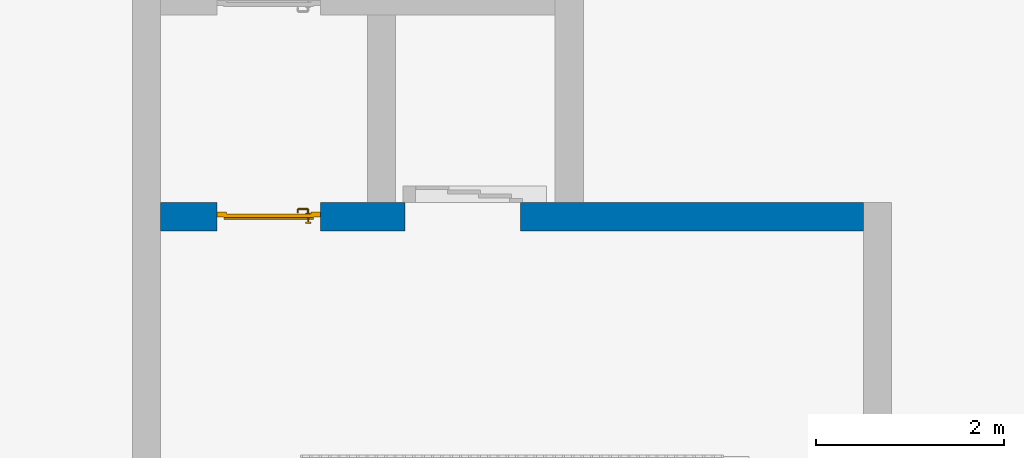
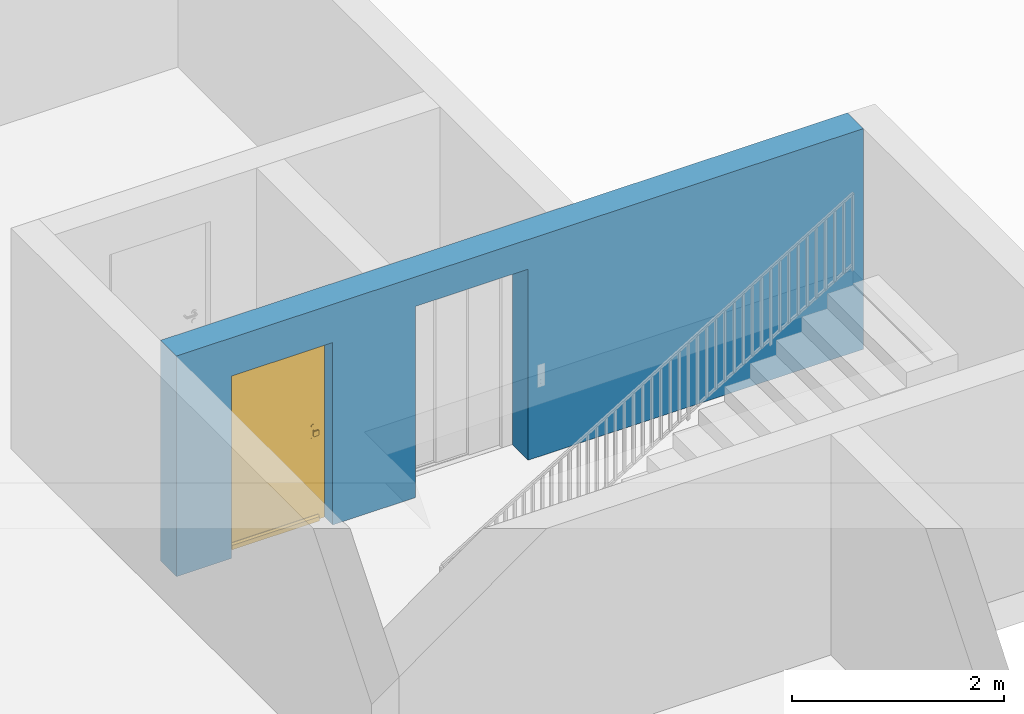
# One storey, part 3 of 6: 1 door, 1 wall, 2 openings.
"""IFC4 building model written with IfcOpenShell, lengths in metres."""

from ifc_helpers import new_model, entity, si_unit, converted_unit, derived_unit, direction, frame, origin_with_axes, place, context, subcontext, project, spatial, polygons, material, type_object, element, fill, save


model = new_model("IFC4")

# Units and contexts
model_context = context("Model", 3, precision=1e-05, world=origin_with_axes(), true_north=direction((0.0, 1.0)))
body_context = subcontext(model_context, "Body", "Model", "MODEL_VIEW")
ifc_project = project(units=[si_unit("LENGTHUNIT", "METRE"), si_unit("AREAUNIT", "SQUARE_METRE"), si_unit("VOLUMEUNIT", "CUBIC_METRE"), converted_unit("PLANEANGLEUNIT", "DEGREE", entity("IfcPlaneAngleMeasure", 0.0174532925199), si_unit("PLANEANGLEUNIT", "RADIAN"), dimensions=[0, 0, 0, 0, 0, 0, 0]), converted_unit("TIMEUNIT", "Year", entity("IfcTimeMeasure", 31556926.0), si_unit("TIMEUNIT", "SECOND"), dimensions=[0, 0, 1, 0, 0, 0, 0]), si_unit("MASSUNIT", "GRAM", prefix="KILO"), si_unit("THERMODYNAMICTEMPERATUREUNIT", "DEGREE_CELSIUS"), si_unit("LUMINOUSINTENSITYUNIT", "LUMEN"), si_unit("ENERGYUNIT", "JOULE", prefix="MEGA"), derived_unit("THERMALCONDUCTANCEUNIT", [(si_unit("POWERUNIT", "WATT"), 1), (si_unit("LENGTHUNIT", "METRE"), -1), (si_unit("THERMODYNAMICTEMPERATUREUNIT", "KELVIN"), -1)]), derived_unit("SPECIFICHEATCAPACITYUNIT", [(si_unit("ENERGYUNIT", "JOULE"), 1), (si_unit("MASSUNIT", "GRAM", prefix="KILO"), -1), (si_unit("THERMODYNAMICTEMPERATUREUNIT", "KELVIN"), -1)]), derived_unit("MASSDENSITYUNIT", [(si_unit("MASSUNIT", "GRAM", prefix="KILO"), 1), (si_unit("VOLUMEUNIT", "CUBIC_METRE"), -1)])], contexts=[model_context])

# Site, building, storey
site_placement = place(None, origin_with_axes())
site = spatial("IfcSite", under=ifc_project, at=site_placement, CompositionType="ELEMENT")
building_placement = place(site_placement, origin_with_axes())
building = spatial("IfcBuilding", under=site, at=building_placement, CompositionType="ELEMENT")
storey_placement = place(building_placement, frame((0.0, 0.0, -2.89), z_axis=(0.0, 0.0, 1.0), x_axis=(1.0, 0.0, 0.0)))
storey = spatial("IfcBuildingStorey", under=building, at=storey_placement, Name="-1. Geschoss", CompositionType="ELEMENT", Elevation=-2.89)

# Wall, openings, door
ifc_material = material()
wall_type = type_object("IfcWallType", Name="300", PredefinedType="NOTDEFINED")
wall_placement = place(storey_placement, frame((-5.2421993804, 1.37118776896, 0.0), z_axis=(0.0, 0.0, 1.0), x_axis=(1.0, 0.0, 0.0)))
wall = element("IfcWall", 1, at=wall_placement, inside=storey, type_object=wall_type, material=ifc_material, Name="Wand-001", PredefinedType="NOTDEFINED", context=body_context, shape_type="Tessellation", body=[
    polygons([(2.9, 0.3, 2.2), (2.9, 0.3, 0.0), (2.0, 0.3, 0.0), (2.0, 0.3, 2.1), (0.9, 0.3, 2.1), (0.9, 0.3, 0.0), (0.3, 0.3, 0.0), (0.3, 0.3, 2.54), (7.78, 0.3, 2.54), (7.78, 0.3, 0.0), (4.13, 0.3, 0.0), (4.13, 0.3, 2.2), (2.9, 0.0, 2.2), (2.9, 0.0, 0.0), (2.0, 0.0, 0.0), (2.0, 0.0, 2.1), (0.9, 0.0, 2.1), (0.9, 0.0, 0.0), (0.3, 0.0, 0.0), (0.3, 0.0, 2.54), (7.78, 0.0, 2.54), (7.78, 0.0, 0.0), (4.13, 0.0, 0.0), (4.13, 0.0, 2.2)], [[[1, 2, 3, 4, 5, 6, 7, 8, 9, 10, 11, 12]], [[2, 1, 13, 14]], [[2, 14, 15, 3]], [[3, 15, 16, 4]], [[4, 16, 17, 5]], [[5, 17, 18, 6]], [[18, 19, 7, 6]], [[7, 19, 20, 8]], [[8, 20, 21, 9]], [[22, 10, 9, 21]], [[23, 11, 10, 22]], [[12, 11, 23, 24]], [[1, 12, 24, 13]], [[24, 23, 22, 21, 20, 19, 18, 17, 16, 15, 14, 13]]], closed=True),
])
opening_1_placement = place(wall_placement, frame((1.45, 0.0, 0.0), z_axis=(0.0, 0.0, 1.0), x_axis=(1.0, 0.0, 0.0)))
opening_1 = element("IfcOpeningElement", 2, at=opening_1_placement, cuts=wall, context=body_context, identifier="Reference", shape_type="Tessellation", body=[
    polygons([(0.55, 0.15, 0.0), (0.55, 0.15, 2.1), (0.55, -0.001, 2.1), (0.55, -0.001, 0.0), (0.55, 0.301, 0.0), (0.55, 0.301, 2.1), (-0.55, 0.15, 2.1), (-0.55, -0.001, 2.1), (-0.55, 0.301, 2.1), (-0.55, -0.001, 0.0), (-0.55, 0.15, 0.0), (-0.55, 0.301, 0.0)], [[[1, 2, 3, 4]], [[2, 1, 5, 6]], [[7, 8, 3, 2, 6, 9]], [[8, 10, 4, 3]], [[1, 4, 10, 11, 12, 5]], [[6, 5, 12, 9]], [[7, 11, 10, 8]], [[11, 7, 9, 12]]], closed=True),
])
opening_2_placement = place(wall_placement, frame((3.515, 0.0, 0.0), z_axis=(0.0, 0.0, 1.0), x_axis=(1.0, 0.0, 0.0)))
element("IfcOpeningElement", 3, at=opening_2_placement, cuts=wall, context=body_context, identifier="Reference", shape_type="Tessellation", body=[
    polygons([(-0.615, -0.001, 2.2), (-0.615, -0.001, 0.0), (0.615, -0.001, 0.0), (0.615, -0.001, 2.2), (-0.615, 0.301, 2.2), (-0.615, 0.301, 0.0), (0.615, 0.301, 0.0), (0.615, 0.301, 2.2)], [[[1, 2, 3, 4]], [[5, 6, 2, 1]], [[6, 7, 3, 2]], [[7, 8, 4, 3]], [[8, 5, 1, 4]], [[7, 6, 5, 8]]], closed=True),
])
door_type = type_object("IfcDoorType", Name="Eingang 01 1-Fl 26", OperationType="SINGLE_SWING_RIGHT", PredefinedType="DOOR")
door_placement = place(opening_1_placement, frame((0.45, 0.0, 0.0), z_axis=(0.0, 0.0, 1.0), x_axis=(-1.0, 0.0, 0.0)))
door = element("IfcDoor", 4, at=door_placement, inside=storey, type_object=door_type, OverallHeight=2.1, OverallWidth=1.1, PredefinedType="DOOR", context=body_context, shape_type="Tessellation", body=[
    polygons([(1.0, -0.2, 0.0), (1.0, -0.18, 0.0), (1.0, -0.18, 2.1), (1.0, -0.2, 2.1), (0.9, -0.2, 0.0), (0.9, -0.18, 0.0), (0.9, -0.18, 2.0), (0.5801, -0.18, 2.0), (0.4501, -0.18, 2.0), (0.0, -0.18, 2.0), (0.0, -0.18, 0.0), (-0.1, -0.18, 0.0), (-0.1, -0.18, 2.1), (-0.1, -0.2, 2.1), (-0.1, -0.2, 0.0), (0.0, -0.2, 0.0), (0.0, -0.2, 2.0), (0.4501, -0.2, 2.0), (0.5801, -0.2, 2.0), (0.9, -0.2, 2.0)], [[[1, 2, 3, 4]], [[5, 6, 2, 1]], [[2, 6, 7, 8, 9, 10, 11, 12, 13, 3]], [[4, 3, 13, 14]], [[1, 4, 14, 15, 16, 17, 18, 19, 20, 5]], [[20, 7, 6, 5]], [[19, 8, 7, 20]], [[18, 9, 8, 19]], [[17, 10, 9, 18]], [[16, 11, 10, 17]], [[15, 12, 11, 16]], [[14, 13, 12, 15]]], closed=True),
    polygons([(1.0, -0.18, 0.0), (1.0, -0.15, 0.0), (1.0, -0.15, 2.1), (1.0, -0.18, 2.1), (0.93, -0.18, 0.0), (0.93, -0.15, 0.0), (0.93, -0.15, 2.03), (0.5501, -0.15, 2.03), (0.4801, -0.15, 2.03), (-0.03, -0.15, 2.03), (-0.03, -0.15, 0.0), (-0.1, -0.15, 0.0), (-0.1, -0.15, 2.1), (-0.1, -0.18, 2.1), (-0.1, -0.18, 0.0), (-0.03, -0.18, 0.0), (-0.03, -0.18, 2.03), (0.4801, -0.18, 2.03), (0.5501, -0.18, 2.03), (0.93, -0.18, 2.03)], [[[1, 2, 3, 4]], [[5, 6, 2, 1]], [[2, 6, 7, 8, 9, 10, 11, 12, 13, 3]], [[4, 3, 13, 14]], [[1, 4, 14, 15, 16, 17, 18, 19, 20, 5]], [[20, 7, 6, 5]], [[19, 8, 7, 20]], [[18, 9, 8, 19]], [[17, 10, 9, 18]], [[16, 11, 10, 17]], [[15, 12, 11, 16]], [[14, 13, 12, 15]]], closed=True),
    polygons([(0.93, -0.14, 0.0), (-0.03, -0.14, 0.0), (-0.03, -0.14, 2.03), (0.93, -0.14, 2.03), (0.93, -0.18, 0.0), (-0.03, -0.18, 0.0), (-0.03, -0.18, 2.03), (0.93, -0.18, 2.03)], [[[1, 2, 3, 4]], [[2, 1, 5, 6]], [[3, 2, 6, 7]], [[4, 3, 7, 8]], [[1, 4, 8, 5]], [[6, 5, 8, 7]]], closed=True),
    polygons([(0.925, -0.12, 0.0), (-0.025, -0.12, 0.0), (-0.025, -0.12, 0.05), (0.925, -0.12, 0.05), (0.925, -0.14, 0.0), (-0.025, -0.14, 0.0), (-0.025, -0.14, 0.07), (-0.025, -0.135, 0.07), (0.925, -0.135, 0.07), (0.925, -0.14, 0.07)], [[[1, 2, 3, 4]], [[5, 6, 2, 1]], [[2, 6, 7, 8, 3]], [[4, 3, 8, 9]], [[1, 4, 9, 10, 5]], [[10, 7, 6, 5]], [[9, 8, 7, 10]]], closed=True),
    polygons([(0.0165, -0.19, 1.0733826859), (0.03, -0.19, 1.077), (0.03, -0.1899, 1.077), (0.0165, -0.1899, 1.0733826859), (0.00661731409782, -0.19, 1.0635), (0.003, -0.19, 1.05), (0.00661731409782, -0.19, 1.0365), (0.0165, -0.19, 1.0266173141), (0.03, -0.19, 1.023), (0.0435, -0.19, 1.0266173141), (0.0533826859022, -0.19, 1.0365), (0.057, -0.19, 1.05), (0.0533826859022, -0.19, 1.0635), (0.0435, -0.19, 1.0733826859), (0.0435, -0.1899, 1.0733826859), (0.03, -0.1801, 1.077), (0.0165, -0.1801, 1.0733826859), (0.00661731409782, -0.1899, 1.0635), (0.003, -0.1899, 1.05), (0.00661731409782, -0.1899, 1.0365), (0.0165, -0.1899, 1.0266173141), (0.03, -0.1899, 1.023), (0.0435, -0.1899, 1.0266173141), (0.0533826859022, -0.1899, 1.0365), (0.057, -0.1899, 1.05), (0.0533826859022, -0.1899, 1.0635), (0.0435, -0.1801, 1.0733826859), (0.03, -0.18, 1.077), (0.0165, -0.18, 1.0733826859), (0.00661731409782, -0.1801, 1.0635), (0.003, -0.1801, 1.05), (0.00661731409782, -0.1801, 1.0365), (0.0165, -0.1801, 1.0266173141), (0.03, -0.1801, 1.023), (0.0435, -0.1801, 1.0266173141), (0.0533826859022, -0.1801, 1.0365), (0.057, -0.1801, 1.05), (0.0533826859022, -0.1801, 1.0635), (0.0435, -0.18, 1.0733826859), (0.0533826859022, -0.18, 1.0635), (0.057, -0.18, 1.05), (0.0533826859022, -0.18, 1.0365), (0.0435, -0.18, 1.0266173141), (0.03, -0.18, 1.023), (0.0165, -0.18, 1.0266173141), (0.00661731409782, -0.18, 1.0365), (0.003, -0.18, 1.05), (0.00661731409782, -0.18, 1.0635)], [[[1, 2, 3, 4]], [[2, 1, 5, 6, 7, 8, 9, 10, 11, 12, 13, 14]], [[2, 14, 15, 3]], [[4, 3, 16, 17]], [[5, 1, 4, 18]], [[6, 5, 18, 19]], [[7, 6, 19, 20]], [[8, 7, 20, 21]], [[9, 8, 21, 22]], [[10, 9, 22, 23]], [[11, 10, 23, 24]], [[12, 11, 24, 25]], [[13, 12, 25, 26]], [[14, 13, 26, 15]], [[3, 15, 27, 16]], [[17, 16, 28, 29]], [[18, 4, 17, 30]], [[19, 18, 30, 31]], [[20, 19, 31, 32]], [[21, 20, 32, 33]], [[22, 21, 33, 34]], [[23, 22, 34, 35]], [[24, 23, 35, 36]], [[25, 24, 36, 37]], [[26, 25, 37, 38]], [[15, 26, 38, 27]], [[16, 27, 39, 28]], [[28, 39, 40, 41, 42, 43, 44, 45, 46, 47, 48, 29]], [[30, 17, 29, 48]], [[31, 30, 48, 47]], [[32, 31, 47, 46]], [[33, 32, 46, 45]], [[34, 33, 45, 44]], [[35, 34, 44, 43]], [[36, 35, 43, 42]], [[37, 36, 42, 41]], [[38, 37, 41, 40]], [[27, 38, 40, 39]]], closed=True),
    polygons([(0.0374678307756, -0.19, 0.959692280177), (0.035, -0.19, 0.9544), (0.035, -0.19, 0.952886751346), (0.0532960833618, -0.19, 0.96345), (0.04345, -0.19, 0.973296083362), (0.0367202454443, -0.19, 0.961639806549), (0.0374678307756, -0.189, 0.959692280177), (0.035, -0.189, 0.9544), (0.035, -0.189, 0.952886751346), (0.035, -0.189, 0.95), (0.035, -0.189, 0.947113248654), (0.035, -0.189, 0.941339745962), (0.035, -0.189, 0.9375), (0.035, -0.19, 0.9375), (0.035, -0.19, 0.941339745962), (0.035, -0.19, 0.947113248654), (0.035, -0.19, 0.95), (0.0569, -0.19, 0.95), (0.0533826859022, -0.19, 0.9635), (0.0435, -0.19, 0.973382685902), (0.035375182315, -0.19, 0.965143815798), (0.03, -0.19, 0.9769), (0.03, -0.19, 0.967425445323), (0.035375182315, -0.189, 0.965143815798), (0.0367202454443, -0.189, 0.961639806549), (0.04295, -0.189, 0.972430057958), (0.052430057958, -0.189, 0.96295), (0.0559, -0.189, 0.95), (0.052430057958, -0.189, 0.93705), (0.04295, -0.189, 0.927569942042), (0.03, -0.189, 0.9241), (0.03, -0.189, 0.9325), (0.0335355339059, -0.189, 0.933964466094), (0.0335355339059, -0.19, 0.933964466094), (0.04345, -0.19, 0.926703916638), (0.03, -0.19, 0.9325), (0.03, -0.19, 0.9231), (0.0532960833618, -0.19, 0.93655), (0.057, -0.19, 0.95), (0.0533826859022, -0.1899, 0.9635), (0.0435, -0.1899, 0.973382685902), (0.03, -0.19, 0.977), (0.024624817685, -0.19, 0.965143815798), (0.01655, -0.19, 0.973296083362), (0.0232797545557, -0.19, 0.961639806549), (0.03, -0.189, 0.967425445323), (0.03, -0.189, 0.9759), (0.043, -0.189, 0.972516660498), (0.0525166604984, -0.189, 0.963), (0.056, -0.189, 0.95), (0.0525166604984, -0.189, 0.937), (0.043, -0.189, 0.927483339502), (0.01705, -0.189, 0.927569942042), (0.025, -0.189, 0.941339745962), (0.025, -0.189, 0.9375), (0.0264644660941, -0.189, 0.933964466094), (0.03, -0.189, 0.924), (0.0264644660941, -0.19, 0.933964466094), (0.025, -0.19, 0.9375), (0.025, -0.19, 0.941339745962), (0.01655, -0.19, 0.926703916638), (0.03, -0.19, 0.923), (0.0435, -0.19, 0.926617314098), (0.0533826859022, -0.19, 0.9365), (0.057, -0.1899, 0.95), (0.0533826859022, -0.1801, 0.9635), (0.0435, -0.1801, 0.973382685902), (0.03, -0.1899, 0.977), (0.0165, -0.19, 0.973382685902), (0.024624817685, -0.189, 0.965143815798), (0.0225321692244, -0.19, 0.959692280177), (0.0067039166382, -0.19, 0.96345), (0.025, -0.19, 0.952886751346), (0.025, -0.19, 0.9544), (0.0225321692244, -0.189, 0.959692280177), (0.0232797545557, -0.189, 0.961639806549), (0.01705, -0.189, 0.972430057958), (0.03, -0.189, 0.976), (0.043, -0.1889, 0.972516660498), (0.0525166604984, -0.1889, 0.963), (0.056, -0.1889, 0.95), (0.0525166604984, -0.1889, 0.937), (0.043, -0.1889, 0.927483339502), (0.00756994204198, -0.189, 0.93705), (0.025, -0.189, 0.947113248654), (0.025, -0.189, 0.9544), (0.025, -0.19, 0.95), (0.025, -0.19, 0.947113248654), (0.025, -0.189, 0.95), (0.025, -0.189, 0.952886751346), (0.017, -0.189, 0.927483339502), (0.03, -0.1889, 0.924), (0.0067039166382, -0.19, 0.93655), (0.0165, -0.19, 0.926617314098), (0.03, -0.1899, 0.923), (0.0435, -0.1899, 0.926617314098), (0.0533826859022, -0.1899, 0.9365), (0.057, -0.1801, 0.95), (0.0533826859022, -0.18, 0.9635), (0.0435, -0.18, 0.973382685902), (0.03, -0.1801, 0.977), (0.0165, -0.1899, 0.973382685902), (0.00661731409782, -0.19, 0.9635), (0.0031, -0.19, 0.95), (0.00756994204198, -0.189, 0.96295), (0.017, -0.189, 0.972516660498), (0.03, -0.1889, 0.976), (0.043, -0.1801, 0.972516660498), (0.0525166604984, -0.1801, 0.963), (0.056, -0.1801, 0.95), (0.0525166604984, -0.1801, 0.937), (0.043, -0.1801, 0.927483339502), (0.0074833395016, -0.189, 0.937), (0.0041, -0.189, 0.95), (0.017, -0.1889, 0.927483339502), (0.03, -0.1801, 0.924), (0.00661731409782, -0.19, 0.9365), (0.0165, -0.1899, 0.926617314098), (0.03, -0.1801, 0.923), (0.0435, -0.1801, 0.926617314098), (0.0533826859022, -0.1801, 0.9365), (0.057, -0.18, 0.95), (0.0532960833618, -0.18, 0.96345), (0.04345, -0.18, 0.973296083362), (0.03, -0.18, 0.977), (0.0165, -0.1801, 0.973382685902), (0.00661731409782, -0.1899, 0.9635), (0.003, -0.19, 0.95), (0.0074833395016, -0.189, 0.963), (0.017, -0.1889, 0.972516660498), (0.03, -0.1801, 0.976), (0.043, -0.18, 0.972516660498), (0.0525166604984, -0.18, 0.963), (0.056, -0.18, 0.95), (0.0525166604984, -0.18, 0.937), (0.043, -0.18, 0.927483339502), (0.0074833395016, -0.1889, 0.937), (0.004, -0.189, 0.95), (0.017, -0.1801, 0.927483339502), (0.03, -0.18, 0.924), (0.00661731409782, -0.1899, 0.9365), (0.0165, -0.1801, 0.926617314098), (0.03, -0.18, 0.923), (0.0435, -0.18, 0.926617314098), (0.0533826859022, -0.18, 0.9365), (0.0569, -0.18, 0.95), (0.0526032630388, -0.18, 0.96305), (0.04305, -0.18, 0.972603263039), (0.03, -0.18, 0.9769), (0.0165, -0.18, 0.973382685902), (0.00661731409782, -0.1801, 0.9635), (0.003, -0.1899, 0.95), (0.0074833395016, -0.1889, 0.963), (0.017, -0.1801, 0.972516660498), (0.03, -0.18, 0.976), (0.0561, -0.18, 0.95), (0.0526032630388, -0.18, 0.93695), (0.04305, -0.18, 0.927396736961), (0.0074833395016, -0.1801, 0.937), (0.004, -0.1889, 0.95), (0.017, -0.18, 0.927483339502), (0.03, -0.18, 0.9239), (0.00661731409782, -0.1801, 0.9365), (0.0165, -0.18, 0.926617314098), (0.03, -0.18, 0.9231), (0.04345, -0.18, 0.926703916638), (0.0532960833618, -0.18, 0.93655), (0.03, -0.18, 0.9761), (0.01655, -0.18, 0.973296083362), (0.00661731409782, -0.18, 0.9635), (0.003, -0.1801, 0.95), (0.0074833395016, -0.1801, 0.963), (0.017, -0.18, 0.972516660498), (0.0074833395016, -0.18, 0.937), (0.004, -0.1801, 0.95), (0.01695, -0.18, 0.927396736961), (0.00661731409782, -0.18, 0.9365), (0.01655, -0.18, 0.926703916638), (0.01695, -0.18, 0.972603263039), (0.0067039166382, -0.18, 0.96345), (0.003, -0.18, 0.95), (0.0074833395016, -0.18, 0.963), (0.00739673696123, -0.18, 0.93695), (0.004, -0.18, 0.95), (0.0067039166382, -0.18, 0.93655), (0.00739673696123, -0.18, 0.96305), (0.0031, -0.18, 0.95), (0.0039, -0.18, 0.95)], [[[1, 2, 3, 4, 5, 6]], [[2, 1, 7, 8]], [[2, 8, 9, 10, 11, 12, 13, 14, 15, 16, 17, 3]], [[17, 18, 4, 3]], [[19, 20, 5, 4]], [[21, 6, 5, 22, 23]], [[1, 6, 21, 24, 25, 7]], [[7, 25, 26, 27, 9, 8]], [[9, 27, 28, 10]], [[10, 28, 29, 11]], [[11, 29, 30, 12]], [[31, 32, 33, 13, 12, 30]], [[14, 13, 33, 34]], [[35, 15, 14, 34, 36, 37]], [[15, 35, 38, 16]], [[16, 38, 18, 17]], [[39, 19, 4, 18]], [[40, 41, 20, 19]], [[20, 42, 22, 5]], [[43, 23, 22, 44, 45]], [[21, 23, 46, 24]], [[24, 46, 47, 26, 25]], [[27, 26, 48, 49]], [[28, 27, 49, 50]], [[29, 28, 50, 51]], [[30, 29, 51, 52]], [[53, 54, 55, 56, 32, 31]], [[34, 33, 32, 36]], [[31, 30, 52, 57]], [[37, 36, 58, 59, 60, 61]], [[62, 63, 35, 37]], [[63, 64, 38, 35]], [[64, 39, 18, 38]], [[65, 40, 19, 39]], [[66, 67, 41, 40]], [[41, 68, 42, 20]], [[42, 69, 44, 22]], [[23, 43, 70, 46]], [[71, 45, 44, 72, 73, 74]], [[43, 45, 71, 75, 76, 70]], [[70, 76, 77, 47, 46]], [[26, 47, 78, 48]], [[49, 48, 79, 80]], [[50, 49, 80, 81]], [[51, 50, 81, 82]], [[52, 51, 82, 83]], [[54, 53, 84, 85]], [[86, 74, 73, 87, 88, 60, 59, 55, 54, 85, 89, 90]], [[58, 56, 55, 59]], [[36, 32, 56, 58]], [[53, 31, 57, 91]], [[57, 52, 83, 92]], [[88, 93, 61, 60]], [[94, 62, 37, 61]], [[95, 96, 63, 62]], [[96, 97, 64, 63]], [[97, 65, 39, 64]], [[98, 66, 40, 65]], [[99, 100, 67, 66]], [[67, 101, 68, 41]], [[68, 102, 69, 42]], [[69, 103, 72, 44]], [[73, 72, 104, 87]], [[71, 74, 86, 75]], [[75, 86, 90, 105, 77, 76]], [[47, 77, 106, 78]], [[48, 78, 107, 79]], [[80, 79, 108, 109]], [[81, 80, 109, 110]], [[82, 81, 110, 111]], [[83, 82, 111, 112]], [[84, 53, 91, 113]], [[85, 84, 114, 89]], [[87, 104, 93, 88]], [[89, 114, 105, 90]], [[91, 57, 92, 115]], [[92, 83, 112, 116]], [[117, 94, 61, 93]], [[118, 95, 62, 94]], [[119, 120, 96, 95]], [[120, 121, 97, 96]], [[121, 98, 65, 97]], [[122, 99, 66, 98]], [[123, 124, 100, 99]], [[100, 125, 101, 67]], [[101, 126, 102, 68]], [[102, 127, 103, 69]], [[103, 128, 104, 72]], [[77, 105, 129, 106]], [[78, 106, 130, 107]], [[79, 107, 131, 108]], [[109, 108, 132, 133]], [[110, 109, 133, 134]], [[111, 110, 134, 135]], [[112, 111, 135, 136]], [[113, 91, 115, 137]], [[114, 84, 113, 138]], [[128, 117, 93, 104]], [[105, 114, 138, 129]], [[115, 92, 116, 139]], [[116, 112, 136, 140]], [[141, 118, 94, 117]], [[142, 119, 95, 118]], [[143, 144, 120, 119]], [[144, 145, 121, 120]], [[145, 122, 98, 121]], [[146, 123, 99, 122]], [[147, 148, 124, 123]], [[124, 149, 125, 100]], [[125, 150, 126, 101]], [[126, 151, 127, 102]], [[127, 152, 128, 103]], [[106, 129, 153, 130]], [[107, 130, 154, 131]], [[108, 131, 155, 132]], [[133, 132, 148, 147]], [[134, 133, 147, 156]], [[135, 134, 156, 157]], [[136, 135, 157, 158]], [[137, 115, 139, 159]], [[138, 113, 137, 160]], [[152, 141, 117, 128]], [[129, 138, 160, 153]], [[139, 116, 140, 161]], [[140, 136, 158, 162]], [[163, 142, 118, 141]], [[164, 143, 119, 142]], [[165, 166, 144, 143]], [[166, 167, 145, 144]], [[167, 146, 122, 145]], [[156, 147, 123, 146]], [[148, 168, 149, 124]], [[149, 169, 150, 125]], [[150, 170, 151, 126]], [[151, 171, 152, 127]], [[130, 153, 172, 154]], [[131, 154, 173, 155]], [[132, 155, 168, 148]], [[157, 156, 146, 167]], [[158, 157, 167, 166]], [[159, 139, 161, 174]], [[160, 137, 159, 175]], [[171, 163, 141, 152]], [[153, 160, 175, 172]], [[161, 140, 162, 176]], [[162, 158, 166, 165]], [[177, 164, 142, 163]], [[178, 165, 143, 164]], [[168, 179, 169, 149]], [[169, 180, 170, 150]], [[170, 181, 171, 151]], [[154, 172, 182, 173]], [[155, 173, 179, 168]], [[174, 161, 176, 183]], [[175, 159, 174, 184]], [[181, 177, 163, 171]], [[172, 175, 184, 182]], [[176, 162, 165, 178]], [[185, 178, 164, 177]], [[179, 186, 180, 169]], [[180, 187, 181, 170]], [[173, 182, 186, 179]], [[183, 176, 178, 185]], [[184, 174, 183, 188]], [[187, 185, 177, 181]], [[182, 184, 188, 186]], [[186, 188, 187, 180]], [[188, 183, 185, 187]]], closed=True),
    polygons([(0.02, -0.19, 1.05), (0.0229289321881, -0.19, 1.04292893219), (0.0229289321881, -0.220696439392, 1.04292893219), (0.02, -0.220984914034, 1.05), (0.03, -0.19, 1.04), (0.03, -0.22, 1.04), (0.0244810067792, -0.228499245278, 1.04292893219), (0.0217220129863, -0.229642057926, 1.05), (0.0229289321881, -0.19, 1.05707106781), (0.0229289321881, -0.220696439392, 1.05707106781), (0.0370710678119, -0.19, 1.04292893219), (0.0370710678119, -0.219303560608, 1.04292893219), (0.0311418070123, -0.225740251485, 1.04), (0.0292954424912, -0.235704557509, 1.04292893219), (0.0271838000621, -0.237816199938, 1.05), (0.0244810067792, -0.228499245278, 1.05707106781), (0.03, -0.19, 1.06), (0.03, -0.22, 1.06), (0.04, -0.19, 1.05), (0.04, -0.219015085966, 1.05), (0.0378026072455, -0.222981257693, 1.04292893219), (0.0343933982822, -0.230606601718, 1.04), (0.0365007547217, -0.240518993221, 1.04292893219), (0.0353579420742, -0.243277987014, 1.05), (0.0292954424912, -0.235704557509, 1.05707106781), (0.0311418070123, -0.225740251485, 1.06), (0.0370710678119, -0.19, 1.05707106781), (0.0370710678119, -0.219303560608, 1.05707106781), (0.0405616010383, -0.221838445045, 1.05), (0.0394913540732, -0.225508645927, 1.04292893219), (0.0392597485145, -0.233858192988, 1.04), (0.044303560608, -0.242071067812, 1.04292893219), (0.0440150859664, -0.245, 1.05), (0.0365007547217, -0.240518993221, 1.05707106781), (0.0343933982822, -0.230606601718, 1.06), (0.0378026072455, -0.222981257693, 1.05707106781), (0.0416029965023, -0.223397003498, 1.05), (0.0420187423074, -0.227197392755, 1.04292893219), (0.045, -0.235, 1.04), (0.125696439392, -0.242071067812, 1.04292893219), (0.125984914034, -0.245, 1.05), (0.044303560608, -0.242071067812, 1.05707106781), (0.0392597485145, -0.233858192988, 1.06), (0.0394913540732, -0.225508645927, 1.05707106781), (0.0431615549548, -0.224438398962, 1.05), (0.045696439392, -0.227928932188, 1.04292893219), (0.125, -0.235, 1.04), (0.133499245278, -0.240518993221, 1.04292893219), (0.134642057926, -0.243277987014, 1.05), (0.125696439392, -0.242071067812, 1.05707106781), (0.045, -0.235, 1.06), (0.0420187423074, -0.227197392755, 1.05707106781), (0.0459849140336, -0.225, 1.05), (0.124303560608, -0.227928932188, 1.04292893219), (0.130740251485, -0.233858192988, 1.04), (0.140704557509, -0.235704557509, 1.04292893219), (0.142816199938, -0.237816199938, 1.05), (0.133499245278, -0.240518993221, 1.05707106781), (0.125, -0.235, 1.06), (0.045696439392, -0.227928932188, 1.05707106781), (0.124015085966, -0.225, 1.05), (0.127981257693, -0.227197392755, 1.04292893219), (0.135606601718, -0.230606601718, 1.04), (0.145518993221, -0.228499245278, 1.04292893219), (0.148277987014, -0.229642057926, 1.05), (0.140704557509, -0.235704557509, 1.05707106781), (0.130740251485, -0.233858192988, 1.06), (0.124303560608, -0.227928932188, 1.05707106781), (0.126838445045, -0.224438398962, 1.05), (0.130508645927, -0.225508645927, 1.04292893219), (0.138858192988, -0.225740251485, 1.04), (0.147071067812, -0.220696439392, 1.04292893219), (0.15, -0.220984914034, 1.05), (0.145518993221, -0.228499245278, 1.05707106781), (0.135606601718, -0.230606601718, 1.06), (0.127981257693, -0.227197392755, 1.05707106781), (0.128397003498, -0.223397003498, 1.05), (0.132197392755, -0.222981257693, 1.04292893219), (0.14, -0.22, 1.04), (0.147071067812, -0.19, 1.04292893219), (0.15, -0.19, 1.05), (0.147071067812, -0.220696439392, 1.05707106781), (0.138858192988, -0.225740251485, 1.06), (0.130508645927, -0.225508645927, 1.05707106781), (0.129438398962, -0.221838445045, 1.05), (0.132928932188, -0.219303560608, 1.04292893219), (0.14, -0.19, 1.04), (0.132928932188, -0.19, 1.04292893219), (0.13, -0.19, 1.05), (0.132928932188, -0.19, 1.05707106781), (0.14, -0.19, 1.06), (0.147071067812, -0.19, 1.05707106781), (0.14, -0.22, 1.06), (0.132197392755, -0.222981257693, 1.05707106781), (0.13, -0.219015085966, 1.05), (0.132928932188, -0.219303560608, 1.05707106781)], [[[1, 2, 3, 4]], [[2, 5, 6, 3]], [[4, 3, 7, 8]], [[9, 1, 4, 10]], [[5, 11, 12, 6]], [[3, 6, 13, 7]], [[8, 7, 14, 15]], [[10, 4, 8, 16]], [[17, 9, 10, 18]], [[11, 19, 20, 12]], [[6, 12, 21, 13]], [[7, 13, 22, 14]], [[15, 14, 23, 24]], [[16, 8, 15, 25]], [[18, 10, 16, 26]], [[27, 17, 18, 28]], [[19, 27, 28, 20]], [[12, 20, 29, 21]], [[13, 21, 30, 22]], [[14, 22, 31, 23]], [[24, 23, 32, 33]], [[25, 15, 24, 34]], [[26, 16, 25, 35]], [[28, 18, 26, 36]], [[20, 28, 36, 29]], [[21, 29, 37, 30]], [[22, 30, 38, 31]], [[23, 31, 39, 32]], [[33, 32, 40, 41]], [[34, 24, 33, 42]], [[35, 25, 34, 43]], [[36, 26, 35, 44]], [[29, 36, 44, 37]], [[30, 37, 45, 38]], [[31, 38, 46, 39]], [[32, 39, 47, 40]], [[41, 40, 48, 49]], [[42, 33, 41, 50]], [[43, 34, 42, 51]], [[44, 35, 43, 52]], [[37, 44, 52, 45]], [[38, 45, 53, 46]], [[39, 46, 54, 47]], [[40, 47, 55, 48]], [[49, 48, 56, 57]], [[50, 41, 49, 58]], [[51, 42, 50, 59]], [[52, 43, 51, 60]], [[45, 52, 60, 53]], [[46, 53, 61, 54]], [[47, 54, 62, 55]], [[48, 55, 63, 56]], [[57, 56, 64, 65]], [[58, 49, 57, 66]], [[59, 50, 58, 67]], [[60, 51, 59, 68]], [[53, 60, 68, 61]], [[54, 61, 69, 62]], [[55, 62, 70, 63]], [[56, 63, 71, 64]], [[65, 64, 72, 73]], [[66, 57, 65, 74]], [[67, 58, 66, 75]], [[68, 59, 67, 76]], [[61, 68, 76, 69]], [[62, 69, 77, 70]], [[63, 70, 78, 71]], [[64, 71, 79, 72]], [[73, 72, 80, 81]], [[74, 65, 73, 82]], [[75, 66, 74, 83]], [[76, 67, 75, 84]], [[69, 76, 84, 77]], [[70, 77, 85, 78]], [[71, 78, 86, 79]], [[72, 79, 87, 80]], [[81, 80, 87, 88, 89, 90, 91, 92]], [[82, 73, 81, 92]], [[83, 74, 82, 93]], [[84, 75, 83, 94]], [[77, 84, 94, 85]], [[78, 85, 95, 86]], [[79, 86, 88, 87]], [[86, 95, 89, 88]], [[95, 96, 90, 89]], [[96, 93, 91, 90]], [[93, 82, 92, 91]], [[94, 83, 93, 96]], [[85, 94, 96, 95]]], closed=False),
    polygons([(0.0353033008589, -0.135, 1.04469669914), (0.0375, -0.135, 1.05), (0.0353033008589, -0.135, 1.05530330086), (0.03, -0.135, 1.0575), (0.0246966991411, -0.135, 1.05530330086), (0.0225, -0.135, 1.05), (0.0246966991411, -0.135, 1.04469669914), (0.03, -0.135, 1.0425), (0.0353033008589, -0.095, 1.04469669914), (0.0375, -0.095, 1.05), (0.0353033008589, -0.095, 1.05530330086), (0.03, -0.095, 1.0575), (0.0246966991411, -0.095, 1.05530330086), (0.0225, -0.095, 1.05), (0.0246966991411, -0.095, 1.04469669914), (0.03, -0.095, 1.0425)], [[[1, 2, 3, 4, 5, 6, 7, 8]], [[1, 9, 10, 2]], [[2, 10, 11, 3]], [[3, 11, 12, 4]], [[4, 12, 13, 5]], [[5, 13, 14, 6]], [[6, 14, 15, 7]], [[7, 15, 16, 8]], [[8, 16, 9, 1]], [[9, 16, 15, 14, 13, 12, 11, 10]]], closed=True),
    polygons([(0.005, -0.14, 0.975), (0.005, -0.135, 0.975), (0.00690301168722, -0.135, 0.965432914191), (0.00690301168722, -0.14, 0.965432914191), (0.005, -0.14, 1.1), (0.005, -0.135, 1.1), (0.00690301168722, -0.135, 1.10956708581), (0.0123223304703, -0.135, 1.11767766953), (0.0204329141909, -0.135, 1.12309698831), (0.03, -0.135, 1.125), (0.0395670858091, -0.135, 1.12309698831), (0.0476776695297, -0.135, 1.11767766953), (0.0530969883128, -0.135, 1.10956708581), (0.055, -0.135, 1.1), (0.055, -0.135, 0.975), (0.0530969883128, -0.135, 0.965432914191), (0.0476776695297, -0.135, 0.95732233047), (0.0395670858091, -0.135, 0.951903011687), (0.03, -0.135, 0.95), (0.0204329141909, -0.135, 0.951903011687), (0.0123223304703, -0.135, 0.95732233047), (0.0123223304703, -0.14, 0.95732233047), (0.0204329141909, -0.14, 0.951903011687), (0.03, -0.14, 0.95), (0.0395670858091, -0.14, 0.951903011687), (0.0476776695297, -0.14, 0.95732233047), (0.0530969883128, -0.14, 0.965432914191), (0.055, -0.14, 0.975), (0.055, -0.14, 1.1), (0.0530969883128, -0.14, 1.10956708581), (0.0476776695297, -0.14, 1.11767766953), (0.0395670858091, -0.14, 1.12309698831), (0.03, -0.14, 1.125), (0.0204329141909, -0.14, 1.12309698831), (0.0123223304703, -0.14, 1.11767766953), (0.00690301168722, -0.14, 1.10956708581)], [[[1, 2, 3, 4]], [[5, 6, 2, 1]], [[2, 6, 7, 8, 9, 10, 11, 12, 13, 14, 15, 16, 17, 18, 19, 20, 21, 3]], [[4, 3, 21, 22]], [[1, 4, 22, 23, 24, 25, 26, 27, 28, 29, 30, 31, 32, 33, 34, 35, 36, 5]], [[36, 7, 6, 5]], [[35, 8, 7, 36]], [[34, 9, 8, 35]], [[33, 10, 9, 34]], [[32, 11, 10, 33]], [[31, 12, 11, 32]], [[30, 13, 12, 31]], [[29, 14, 13, 30]], [[28, 15, 14, 29]], [[27, 16, 15, 28]], [[26, 17, 16, 27]], [[25, 18, 17, 26]], [[24, 19, 18, 25]], [[23, 20, 19, 24]], [[22, 21, 20, 23]]], closed=True),
    polygons([(0.01, -0.095, 1.08), (0.01, -0.08, 1.08), (0.005, -0.08, 1.07866025404), (0.005, -0.095, 1.07866025404), (0.05, -0.095, 1.08), (0.05, -0.08, 1.08), (0.055, -0.08, 1.07866025404), (0.0586602540378, -0.08, 1.075), (0.06, -0.08, 1.07), (0.06, -0.08, 1.03), (0.0586602540378, -0.08, 1.025), (0.055, -0.08, 1.02133974596), (0.05, -0.08, 1.02), (0.01, -0.08, 1.02), (0.005, -0.08, 1.02133974596), (0.00133974596216, -0.08, 1.025), (0.0, -0.08, 1.03), (0.0, -0.08, 1.07), (0.00133974596216, -0.08, 1.075), (0.00133974596216, -0.095, 1.075), (0.0, -0.095, 1.07), (0.0, -0.095, 1.03), (0.00133974596216, -0.095, 1.025), (0.005, -0.095, 1.02133974596), (0.01, -0.095, 1.02), (0.05, -0.095, 1.02), (0.055, -0.095, 1.02133974596), (0.0586602540378, -0.095, 1.025), (0.06, -0.095, 1.03), (0.06, -0.095, 1.07), (0.0586602540378, -0.095, 1.075), (0.055, -0.095, 1.07866025404)], [[[1, 2, 3, 4]], [[5, 6, 2, 1]], [[2, 6, 7, 8, 9, 10, 11, 12, 13, 14, 15, 16, 17, 18, 19, 3]], [[4, 3, 19, 20]], [[1, 4, 20, 21, 22, 23, 24, 25, 26, 27, 28, 29, 30, 31, 32, 5]], [[32, 7, 6, 5]], [[31, 8, 7, 32]], [[30, 9, 8, 31]], [[29, 10, 9, 30]], [[28, 11, 10, 29]], [[27, 12, 11, 28]], [[26, 13, 12, 27]], [[25, 14, 13, 26]], [[24, 15, 14, 25]], [[23, 16, 15, 24]], [[22, 17, 16, 23]], [[21, 18, 17, 22]], [[20, 19, 18, 21]]], closed=True),
])
fill(opening_1, door)

save(model, "model.ifc")
